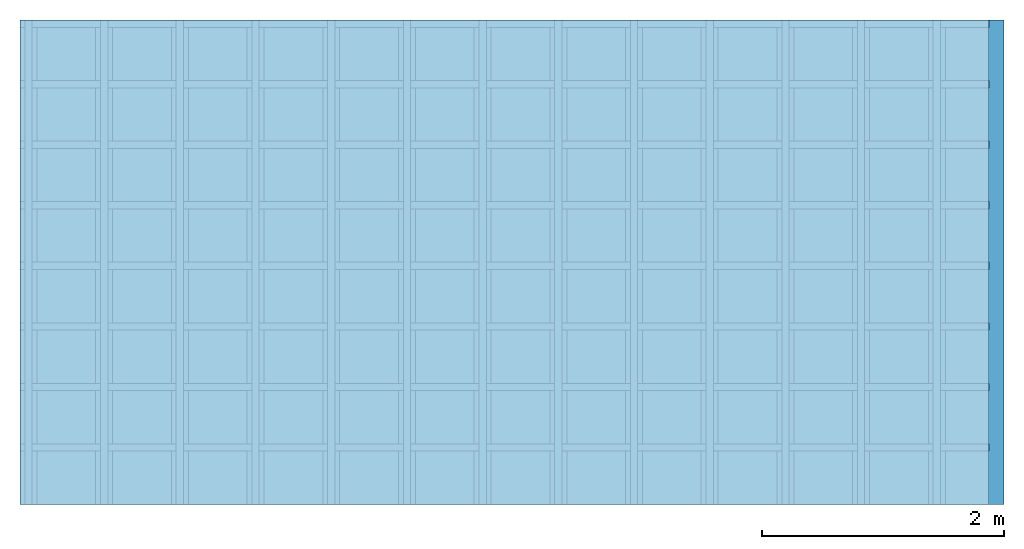
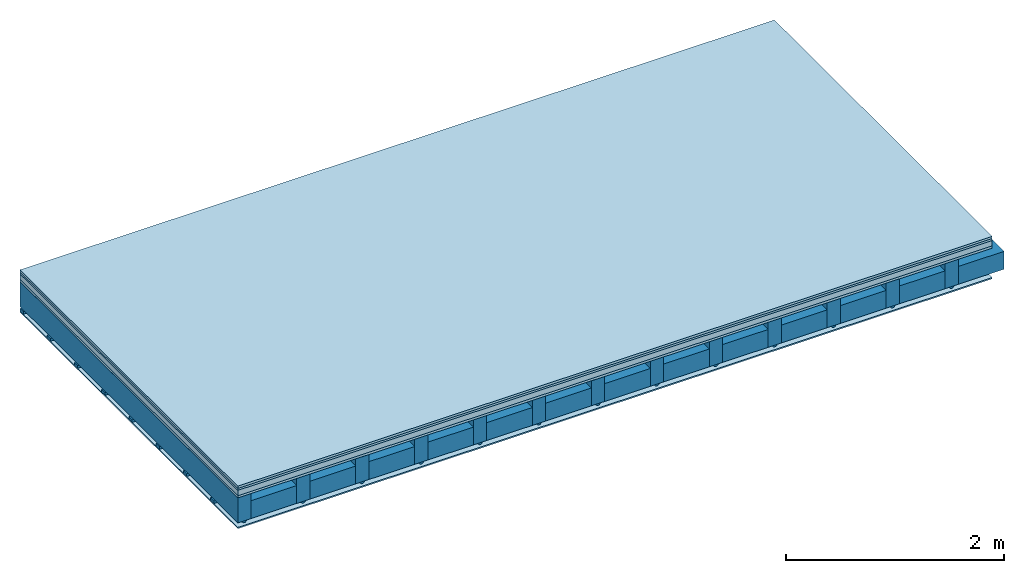
# One storey: 5 plates, 4 members, 1 element without a shape of its own.
"""IFC4 building model written with IfcOpenShell, lengths in metres."""

from ifc_helpers import new_model, si_unit, derived_unit, direction, frame, frame_2d, origin, origin_with_axes, place, context, project, spatial, polyline, rectangle, outline, extrude, material, layer, layer_set, type_object, element, aggregate, save


model = new_model("IFC4")

# Units and contexts
plan_context = context("Plan", 3, precision=1e-05, world=origin(), true_north=direction((0.0, 1.0)))
model_context = context("Model", 3, precision=1e-05, world=origin(), true_north=direction((0.0, 1.0)))
ifc_project = project(units=[si_unit("LENGTHUNIT", "METRE"), derived_unit("SOUNDPRESSUREUNIT", [(si_unit("PRESSUREUNIT", "PASCAL", prefix="MICRO"), 0)]), si_unit("ENERGYUNIT", "JOULE", prefix="MEGA"), si_unit("MASSUNIT", "GRAM", prefix="KILO"), derived_unit("THERMALTRANSMITTANCEUNIT", [(si_unit("POWERUNIT", "WATT"), 1), (si_unit("AREAUNIT", "SQUARE_METRE"), -1), (si_unit("THERMODYNAMICTEMPERATUREUNIT", "KELVIN"), -1)]), derived_unit("AREADENSITYUNIT", [(si_unit("MASSUNIT", "GRAM", prefix="KILO"), 1), (si_unit("AREAUNIT", "SQUARE_METRE"), -1)]), derived_unit("USERDEFINED", [(si_unit("ENERGYUNIT", "JOULE", prefix="MEGA"), 1), (si_unit("AREAUNIT", "SQUARE_METRE"), -1)])], contexts=[plan_context, model_context])

# Site, building, storey
site = spatial("IfcSite", under=ifc_project)
building_placement = place(None, origin())
building = spatial("IfcBuilding", under=site, at=building_placement)
storey_placement = place(building_placement, origin())
storey = spatial("IfcBuildingStorey", under=building, at=storey_placement)

# Slab, members, plates
ifc_material_1 = material(Name="Floor heating system Therm38 longitudinal", Category="03.007")
ifc_layer_1 = layer(ifc_material_1, 0.025, Name="On-material")
ifc_material_2 = material(Category="10.009")
ifc_layer_2 = layer(ifc_material_2, 0.022, Name="Impact sound insulation")
ifc_material_3 = material(Category="03.011")
ifc_layer_3 = layer(ifc_material_3, 0.06, Name="on Supporting structure")
ifc_material_4 = material(Category="07.001")
ifc_layer_4 = layer(ifc_material_4, 0.025, Name="Sub-floor")
ifc_material_5 = material(Name="of the art")
ifc_layer_5 = layer(ifc_material_5, 0.0, Name="Bond")
ifc_layer_6 = layer(None, 0.28, Name="Supporting structure")
ifc_material_6 = material(Name="no composite action")
ifc_layer_7 = layer(ifc_material_6, 0.0, Name="Bond")
ifc_layer_8 = layer(None, 0.02, Name="Coupling")
ifc_layer_9 = layer(None, 0.03, Name="Battens / profiles")
ifc_material_7 = material(Category="03.007")
ifc_layer_10 = layer(ifc_material_7, 0.015, Name="Ceiling covering 1st layer")
ifc_material_8 = material(Name="Glued joints")
ifc_layer_11 = layer(ifc_material_8, 0.0, Name="Surface / treatment")
ifc_layer_set = layer_set([ifc_layer_1, ifc_layer_2, ifc_layer_3, ifc_layer_4, ifc_layer_5, ifc_layer_6, ifc_layer_7, ifc_layer_8, ifc_layer_9, ifc_layer_10, ifc_layer_11])
slab_type = type_object("IfcSlabType", Name="A0268", PredefinedType="NOTDEFINED", material=ifc_layer_set)
slab_placement = place(None, frame((0.0, 0.0, 0.0), z_axis=(0.0, 0.0, -1.0), x_axis=(1.0, 0.0, 0.0)))
slab = element("IfcSlab", 1, at=slab_placement, inside=storey, type_object=slab_type, material=ifc_layer_set, Name="Slab #1")
ifc_material_9 = material()
member_1_placement = place(slab_placement, origin())
member_1 = element("IfcMember", 2, at=member_1_placement, material=ifc_material_9, Name="Supporting structure", context=plan_context, shape_type="SweptSolid", body=[
    extrude(rectangle(XDim=0.14, YDim=0.28, at=frame_2d((0.07, 0.14), x_axis=(1.0, 0.0))), frame((0.0, 4.0, 0.132), z_axis=(0.0, -1.0, 0.0), x_axis=(1.0, 0.0, 0.0)), (0.0, 0.0, 1.0), 4.0),
    extrude(rectangle(XDim=0.14, YDim=0.28, at=frame_2d((0.07, 0.14), x_axis=(1.0, 0.0))), frame((0.625, 4.0, 0.132), z_axis=(0.0, -1.0, 0.0), x_axis=(1.0, 0.0, 0.0)), (0.0, 0.0, 1.0), 4.0),
    extrude(rectangle(XDim=0.14, YDim=0.28, at=frame_2d((0.07, 0.14), x_axis=(1.0, 0.0))), frame((1.25, 4.0, 0.132), z_axis=(0.0, -1.0, 0.0), x_axis=(1.0, 0.0, 0.0)), (0.0, 0.0, 1.0), 4.0),
    extrude(rectangle(XDim=0.14, YDim=0.28, at=frame_2d((0.07, 0.14), x_axis=(1.0, 0.0))), frame((1.875, 4.0, 0.132), z_axis=(0.0, -1.0, 0.0), x_axis=(1.0, 0.0, 0.0)), (0.0, 0.0, 1.0), 4.0),
    extrude(rectangle(XDim=0.14, YDim=0.28, at=frame_2d((0.07, 0.14), x_axis=(1.0, 0.0))), frame((2.5, 4.0, 0.132), z_axis=(0.0, -1.0, 0.0), x_axis=(1.0, 0.0, 0.0)), (0.0, 0.0, 1.0), 4.0),
    extrude(rectangle(XDim=0.14, YDim=0.28, at=frame_2d((0.07, 0.14), x_axis=(1.0, 0.0))), frame((3.125, 4.0, 0.132), z_axis=(0.0, -1.0, 0.0), x_axis=(1.0, 0.0, 0.0)), (0.0, 0.0, 1.0), 4.0),
    extrude(rectangle(XDim=0.14, YDim=0.28, at=frame_2d((0.07, 0.14), x_axis=(1.0, 0.0))), frame((3.75, 4.0, 0.132), z_axis=(0.0, -1.0, 0.0), x_axis=(1.0, 0.0, 0.0)), (0.0, 0.0, 1.0), 4.0),
    extrude(rectangle(XDim=0.14, YDim=0.28, at=frame_2d((0.07, 0.14), x_axis=(1.0, 0.0))), frame((4.375, 4.0, 0.132), z_axis=(0.0, -1.0, 0.0), x_axis=(1.0, 0.0, 0.0)), (0.0, 0.0, 1.0), 4.0),
    extrude(rectangle(XDim=0.14, YDim=0.28, at=frame_2d((0.07, 0.14), x_axis=(1.0, 0.0))), frame((5.0, 4.0, 0.132), z_axis=(0.0, -1.0, 0.0), x_axis=(1.0, 0.0, 0.0)), (0.0, 0.0, 1.0), 4.0),
    extrude(rectangle(XDim=0.14, YDim=0.28, at=frame_2d((0.07, 0.14), x_axis=(1.0, 0.0))), frame((5.625, 4.0, 0.132), z_axis=(0.0, -1.0, 0.0), x_axis=(1.0, 0.0, 0.0)), (0.0, 0.0, 1.0), 4.0),
    extrude(rectangle(XDim=0.14, YDim=0.28, at=frame_2d((0.07, 0.14), x_axis=(1.0, 0.0))), frame((6.25, 4.0, 0.132), z_axis=(0.0, -1.0, 0.0), x_axis=(1.0, 0.0, 0.0)), (0.0, 0.0, 1.0), 4.0),
    extrude(rectangle(XDim=0.14, YDim=0.28, at=frame_2d((0.07, 0.14), x_axis=(1.0, 0.0))), frame((6.875, 4.0, 0.132), z_axis=(0.0, -1.0, 0.0), x_axis=(1.0, 0.0, 0.0)), (0.0, 0.0, 1.0), 4.0),
    extrude(rectangle(XDim=0.14, YDim=0.28, at=frame_2d((0.07, 0.14), x_axis=(1.0, 0.0))), frame((7.5, 4.0, 0.132), z_axis=(0.0, -1.0, 0.0), x_axis=(1.0, 0.0, 0.0)), (0.0, 0.0, 1.0), 4.0),
])
ifc_material_10 = material()
member_2_placement = place(slab_placement, origin())
member_2 = element("IfcMember", 3, at=member_2_placement, material=ifc_material_10, Name="Cavity", context=plan_context, shape_type="SweptSolid", body=[
    extrude(rectangle(XDim=0.485, YDim=0.2, at=frame_2d((0.2425, 0.1), x_axis=(1.0, 0.0))), frame((0.14, 4.0, 0.212), z_axis=(0.0, -1.0, 0.0), x_axis=(1.0, 0.0, 0.0)), (0.0, 0.0, 1.0), 4.0),
    extrude(rectangle(XDim=0.485, YDim=0.2, at=frame_2d((0.2425, 0.1), x_axis=(1.0, 0.0))), frame((0.765, 4.0, 0.212), z_axis=(0.0, -1.0, 0.0), x_axis=(1.0, 0.0, 0.0)), (0.0, 0.0, 1.0), 4.0),
    extrude(rectangle(XDim=0.485, YDim=0.2, at=frame_2d((0.2425, 0.1), x_axis=(1.0, 0.0))), frame((1.39, 4.0, 0.212), z_axis=(0.0, -1.0, 0.0), x_axis=(1.0, 0.0, 0.0)), (0.0, 0.0, 1.0), 4.0),
    extrude(rectangle(XDim=0.485, YDim=0.2, at=frame_2d((0.2425, 0.1), x_axis=(1.0, 0.0))), frame((2.015, 4.0, 0.212), z_axis=(0.0, -1.0, 0.0), x_axis=(1.0, 0.0, 0.0)), (0.0, 0.0, 1.0), 4.0),
    extrude(rectangle(XDim=0.485, YDim=0.2, at=frame_2d((0.2425, 0.1), x_axis=(1.0, 0.0))), frame((2.64, 4.0, 0.212), z_axis=(0.0, -1.0, 0.0), x_axis=(1.0, 0.0, 0.0)), (0.0, 0.0, 1.0), 4.0),
    extrude(rectangle(XDim=0.485, YDim=0.2, at=frame_2d((0.2425, 0.1), x_axis=(1.0, 0.0))), frame((3.265, 4.0, 0.212), z_axis=(0.0, -1.0, 0.0), x_axis=(1.0, 0.0, 0.0)), (0.0, 0.0, 1.0), 4.0),
    extrude(rectangle(XDim=0.485, YDim=0.2, at=frame_2d((0.2425, 0.1), x_axis=(1.0, 0.0))), frame((3.89, 4.0, 0.212), z_axis=(0.0, -1.0, 0.0), x_axis=(1.0, 0.0, 0.0)), (0.0, 0.0, 1.0), 4.0),
    extrude(rectangle(XDim=0.485, YDim=0.2, at=frame_2d((0.2425, 0.1), x_axis=(1.0, 0.0))), frame((4.515, 4.0, 0.212), z_axis=(0.0, -1.0, 0.0), x_axis=(1.0, 0.0, 0.0)), (0.0, 0.0, 1.0), 4.0),
    extrude(rectangle(XDim=0.485, YDim=0.2, at=frame_2d((0.2425, 0.1), x_axis=(1.0, 0.0))), frame((5.14, 4.0, 0.212), z_axis=(0.0, -1.0, 0.0), x_axis=(1.0, 0.0, 0.0)), (0.0, 0.0, 1.0), 4.0),
    extrude(rectangle(XDim=0.485, YDim=0.2, at=frame_2d((0.2425, 0.1), x_axis=(1.0, 0.0))), frame((5.765, 4.0, 0.212), z_axis=(0.0, -1.0, 0.0), x_axis=(1.0, 0.0, 0.0)), (0.0, 0.0, 1.0), 4.0),
    extrude(rectangle(XDim=0.485, YDim=0.2, at=frame_2d((0.2425, 0.1), x_axis=(1.0, 0.0))), frame((6.39, 4.0, 0.212), z_axis=(0.0, -1.0, 0.0), x_axis=(1.0, 0.0, 0.0)), (0.0, 0.0, 1.0), 4.0),
    extrude(rectangle(XDim=0.485, YDim=0.2, at=frame_2d((0.2425, 0.1), x_axis=(1.0, 0.0))), frame((7.015, 4.0, 0.212), z_axis=(0.0, -1.0, 0.0), x_axis=(1.0, 0.0, 0.0)), (0.0, 0.0, 1.0), 4.0),
    extrude(rectangle(XDim=0.485, YDim=0.2, at=frame_2d((0.2425, 0.1), x_axis=(1.0, 0.0))), frame((7.64, 4.0, 0.212), z_axis=(0.0, -1.0, 0.0), x_axis=(1.0, 0.0, 0.0)), (0.0, 0.0, 1.0), 4.0),
])
ifc_material_11 = material()
member_3_placement = place(slab_placement, origin())
member_3 = element("IfcMember", 4, at=member_3_placement, material=ifc_material_11, Name="Coupling", context=plan_context, shape_type="SweptSolid", body=[
    extrude(outline(polyline([(0.0, 0.0), (0.06, 0.0), (0.04, 0.02), (0.02, 0.02), (0.0, 0.0)])), frame((0.04, 4.0, 0.412), z_axis=(0.0, -1.0, 0.0), x_axis=(1.0, 0.0, 0.0)), (0.0, 0.0, 1.0), 4.0),
    extrude(outline(polyline([(0.0, 0.0), (0.06, 0.0), (0.04, 0.02), (0.02, 0.02), (0.0, 0.0)])), frame((0.665, 4.0, 0.412), z_axis=(0.0, -1.0, 0.0), x_axis=(1.0, 0.0, 0.0)), (0.0, 0.0, 1.0), 4.0),
    extrude(outline(polyline([(0.0, 0.0), (0.06, 0.0), (0.04, 0.02), (0.02, 0.02), (0.0, 0.0)])), frame((1.29, 4.0, 0.412), z_axis=(0.0, -1.0, 0.0), x_axis=(1.0, 0.0, 0.0)), (0.0, 0.0, 1.0), 4.0),
    extrude(outline(polyline([(0.0, 0.0), (0.06, 0.0), (0.04, 0.02), (0.02, 0.02), (0.0, 0.0)])), frame((1.915, 4.0, 0.412), z_axis=(0.0, -1.0, 0.0), x_axis=(1.0, 0.0, 0.0)), (0.0, 0.0, 1.0), 4.0),
    extrude(outline(polyline([(0.0, 0.0), (0.06, 0.0), (0.04, 0.02), (0.02, 0.02), (0.0, 0.0)])), frame((2.54, 4.0, 0.412), z_axis=(0.0, -1.0, 0.0), x_axis=(1.0, 0.0, 0.0)), (0.0, 0.0, 1.0), 4.0),
    extrude(outline(polyline([(0.0, 0.0), (0.06, 0.0), (0.04, 0.02), (0.02, 0.02), (0.0, 0.0)])), frame((3.165, 4.0, 0.412), z_axis=(0.0, -1.0, 0.0), x_axis=(1.0, 0.0, 0.0)), (0.0, 0.0, 1.0), 4.0),
    extrude(outline(polyline([(0.0, 0.0), (0.06, 0.0), (0.04, 0.02), (0.02, 0.02), (0.0, 0.0)])), frame((3.79, 4.0, 0.412), z_axis=(0.0, -1.0, 0.0), x_axis=(1.0, 0.0, 0.0)), (0.0, 0.0, 1.0), 4.0),
    extrude(outline(polyline([(0.0, 0.0), (0.06, 0.0), (0.04, 0.02), (0.02, 0.02), (0.0, 0.0)])), frame((4.415, 4.0, 0.412), z_axis=(0.0, -1.0, 0.0), x_axis=(1.0, 0.0, 0.0)), (0.0, 0.0, 1.0), 4.0),
    extrude(outline(polyline([(0.0, 0.0), (0.06, 0.0), (0.04, 0.02), (0.02, 0.02), (0.0, 0.0)])), frame((5.04, 4.0, 0.412), z_axis=(0.0, -1.0, 0.0), x_axis=(1.0, 0.0, 0.0)), (0.0, 0.0, 1.0), 4.0),
    extrude(outline(polyline([(0.0, 0.0), (0.06, 0.0), (0.04, 0.02), (0.02, 0.02), (0.0, 0.0)])), frame((5.665, 4.0, 0.412), z_axis=(0.0, -1.0, 0.0), x_axis=(1.0, 0.0, 0.0)), (0.0, 0.0, 1.0), 4.0),
    extrude(outline(polyline([(0.0, 0.0), (0.06, 0.0), (0.04, 0.02), (0.02, 0.02), (0.0, 0.0)])), frame((6.29, 4.0, 0.412), z_axis=(0.0, -1.0, 0.0), x_axis=(1.0, 0.0, 0.0)), (0.0, 0.0, 1.0), 4.0),
    extrude(outline(polyline([(0.0, 0.0), (0.06, 0.0), (0.04, 0.02), (0.02, 0.02), (0.0, 0.0)])), frame((6.915, 4.0, 0.412), z_axis=(0.0, -1.0, 0.0), x_axis=(1.0, 0.0, 0.0)), (0.0, 0.0, 1.0), 4.0),
    extrude(outline(polyline([(0.0, 0.0), (0.06, 0.0), (0.04, 0.02), (0.02, 0.02), (0.0, 0.0)])), frame((7.54, 4.0, 0.412), z_axis=(0.0, -1.0, 0.0), x_axis=(1.0, 0.0, 0.0)), (0.0, 0.0, 1.0), 4.0),
])
ifc_material_12 = material()
member_4_placement = place(slab_placement, origin())
member_4 = element("IfcMember", 5, at=member_4_placement, material=ifc_material_12, Name="Battens / profiles", context=plan_context, shape_type="SweptSolid", body=[
    extrude(rectangle(XDim=0.06, YDim=0.03, at=frame_2d((0.03, 0.015), x_axis=(1.0, 0.0))), frame((0.0, 0.0, 0.432), z_axis=(1.0, 0.0, 0.0), x_axis=(0.0, 1.0, 0.0)), (0.0, 0.0, 1.0), 8.0),
    extrude(rectangle(XDim=0.06, YDim=0.03, at=frame_2d((0.03, 0.015), x_axis=(1.0, 0.0))), frame((0.0, 0.5, 0.432), z_axis=(1.0, 0.0, 0.0), x_axis=(0.0, 1.0, 0.0)), (0.0, 0.0, 1.0), 8.0),
    extrude(rectangle(XDim=0.06, YDim=0.03, at=frame_2d((0.03, 0.015), x_axis=(1.0, 0.0))), frame((0.0, 1.0, 0.432), z_axis=(1.0, 0.0, 0.0), x_axis=(0.0, 1.0, 0.0)), (0.0, 0.0, 1.0), 8.0),
    extrude(rectangle(XDim=0.06, YDim=0.03, at=frame_2d((0.03, 0.015), x_axis=(1.0, 0.0))), frame((0.0, 1.5, 0.432), z_axis=(1.0, 0.0, 0.0), x_axis=(0.0, 1.0, 0.0)), (0.0, 0.0, 1.0), 8.0),
    extrude(rectangle(XDim=0.06, YDim=0.03, at=frame_2d((0.03, 0.015), x_axis=(1.0, 0.0))), frame((0.0, 2.0, 0.432), z_axis=(1.0, 0.0, 0.0), x_axis=(0.0, 1.0, 0.0)), (0.0, 0.0, 1.0), 8.0),
    extrude(rectangle(XDim=0.06, YDim=0.03, at=frame_2d((0.03, 0.015), x_axis=(1.0, 0.0))), frame((0.0, 2.5, 0.432), z_axis=(1.0, 0.0, 0.0), x_axis=(0.0, 1.0, 0.0)), (0.0, 0.0, 1.0), 8.0),
    extrude(rectangle(XDim=0.06, YDim=0.03, at=frame_2d((0.03, 0.015), x_axis=(1.0, 0.0))), frame((0.0, 3.0, 0.432), z_axis=(1.0, 0.0, 0.0), x_axis=(0.0, 1.0, 0.0)), (0.0, 0.0, 1.0), 8.0),
    extrude(rectangle(XDim=0.06, YDim=0.03, at=frame_2d((0.03, 0.015), x_axis=(1.0, 0.0))), frame((0.0, 3.5, 0.432), z_axis=(1.0, 0.0, 0.0), x_axis=(0.0, 1.0, 0.0)), (0.0, 0.0, 1.0), 8.0),
])
plate_1_placement = place(slab_placement, origin())
plate_1 = element("IfcPlate", 6, at=plate_1_placement, material=ifc_material_1, Name="On-material", context=plan_context, shape_type="SweptSolid", body=[
    extrude(rectangle(XDim=8.0, YDim=4.0, at=frame_2d((4.0, 2.0), x_axis=(1.0, 0.0))), origin_with_axes(), (0.0, 0.0, 1.0), 0.025),
])
plate_2_placement = place(slab_placement, origin())
plate_2 = element("IfcPlate", 7, at=plate_2_placement, material=ifc_material_2, Name="Impact sound insulation", context=plan_context, shape_type="SweptSolid", body=[
    extrude(rectangle(XDim=8.0, YDim=4.0, at=frame_2d((4.0, 2.0), x_axis=(1.0, 0.0))), frame((0.0, 0.0, 0.025), z_axis=(0.0, 0.0, 1.0), x_axis=(1.0, 0.0, 0.0)), (0.0, 0.0, 1.0), 0.022),
])
plate_3_placement = place(slab_placement, origin())
plate_3 = element("IfcPlate", 8, at=plate_3_placement, material=ifc_material_3, Name="on Supporting structure", context=plan_context, shape_type="SweptSolid", body=[
    extrude(rectangle(XDim=8.0, YDim=4.0, at=frame_2d((4.0, 2.0), x_axis=(1.0, 0.0))), frame((0.0, 0.0, 0.047), z_axis=(0.0, 0.0, 1.0), x_axis=(1.0, 0.0, 0.0)), (0.0, 0.0, 1.0), 0.06),
])
plate_4_placement = place(slab_placement, origin())
plate_4 = element("IfcPlate", 9, at=plate_4_placement, material=ifc_material_4, Name="Sub-floor", context=plan_context, shape_type="SweptSolid", body=[
    extrude(rectangle(XDim=8.0, YDim=4.0, at=frame_2d((4.0, 2.0), x_axis=(1.0, 0.0))), frame((0.0, 0.0, 0.107), z_axis=(0.0, 0.0, 1.0), x_axis=(1.0, 0.0, 0.0)), (0.0, 0.0, 1.0), 0.025),
])
plate_5_placement = place(slab_placement, origin())
plate_5 = element("IfcPlate", 10, at=plate_5_placement, material=ifc_material_7, Name="Ceiling covering 1st layer", context=plan_context, shape_type="SweptSolid", body=[
    extrude(rectangle(XDim=8.0, YDim=4.0, at=frame_2d((4.0, 2.0), x_axis=(1.0, 0.0))), frame((0.0, 0.0, 0.462), z_axis=(0.0, 0.0, 1.0), x_axis=(1.0, 0.0, 0.0)), (0.0, 0.0, 1.0), 0.015),
])
aggregate(slab, [plate_1, plate_2, plate_3, plate_4, member_1, member_2, member_3, member_4, plate_5])

save(model, "model.ifc")
